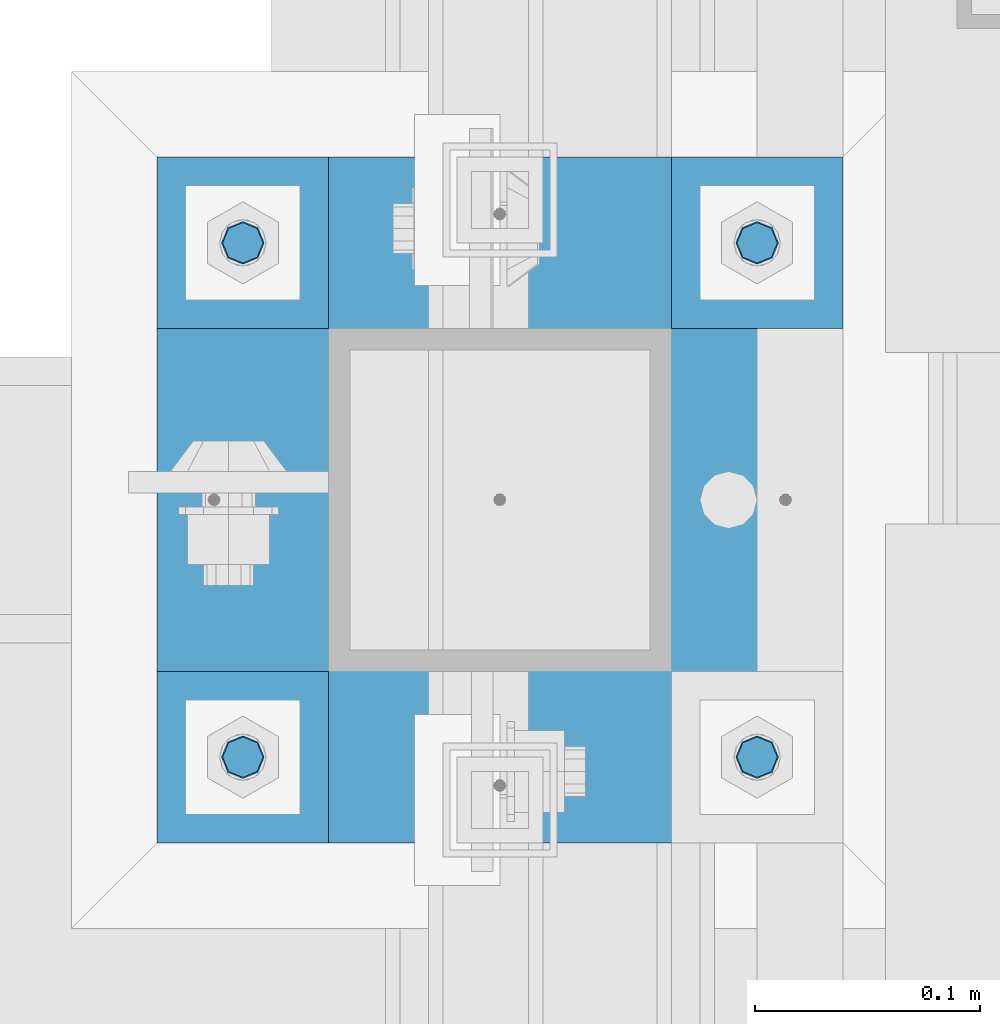
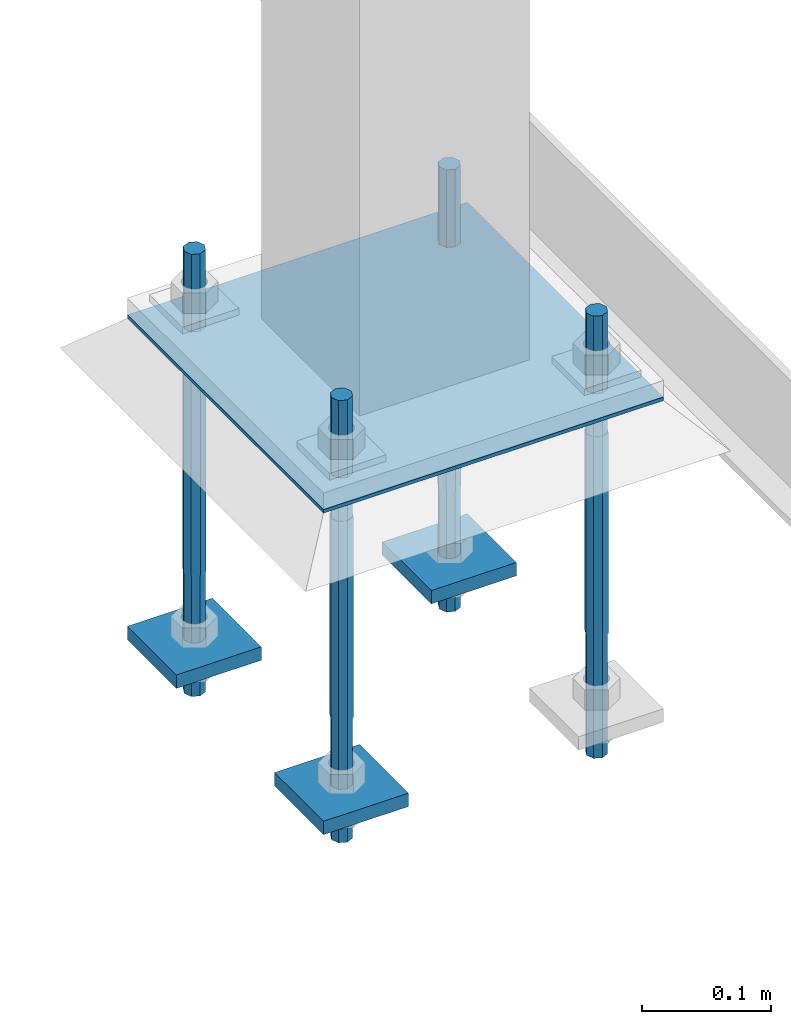
# One storey, part 2070 of 3843: 8 beams, 1 element without a shape of its own.
"""IFC2X3 building model written with IfcOpenShell, lengths in millimetres."""

from ifc_helpers import new_model, si_unit, frame, origin_with_axes, place, context, subcontext, project, spatial, faceted_brep, material, type_object, element, aggregate, save


model = new_model("IFC2X3")

# Units and contexts
model_context = context("Model", 3, precision=1e-05, world=origin_with_axes())
body_context = subcontext(model_context, "Body", "Model", "MODEL_VIEW")
ifc_project = project(units=[si_unit("LENGTHUNIT", "METRE", prefix="MILLI"), si_unit("AREAUNIT", "SQUARE_METRE"), si_unit("VOLUMEUNIT", "CUBIC_METRE"), si_unit("MASSUNIT", "GRAM", prefix="KILO"), si_unit("TIMEUNIT", "SECOND"), si_unit("PLANEANGLEUNIT", "RADIAN"), si_unit("SOLIDANGLEUNIT", "STERADIAN"), si_unit("THERMODYNAMICTEMPERATUREUNIT", "DEGREE_CELSIUS"), si_unit("LUMINOUSINTENSITYUNIT", "LUMEN")], contexts=[model_context])

# Site, building, storey
site_placement = place(None, origin_with_axes())
site = spatial("IfcSite", under=ifc_project, at=site_placement, CompositionType="ELEMENT")
building_placement = place(site_placement, origin_with_axes())
building = spatial("IfcBuilding", under=site, at=building_placement, Name="Undefined", CompositionType="ELEMENT")
storey_placement = place(building_placement, origin_with_axes())
storey = spatial("IfcBuildingStorey", under=building, at=storey_placement, Name="Undefined", CompositionType="ELEMENT", Elevation=0.0)

# Assembly, beams
assembly_placement = place(storey_placement, origin_with_axes())
assembly = element("IfcElementAssembly", 1, at=assembly_placement, inside=storey, Name="TEMPLATE", AssemblyPlace="NOTDEFINED", PredefinedType="RIGID_FRAME")
ifc_material_1 = material(Name="Undefined/F1554-GR.55")
beam_type_1 = type_object("IfcBeamType", PredefinedType="NOTDEFINED")
beam_1_placement = place(assembly_placement, frame((53105.05, 20193.0, 30480.0), z_axis=(1.0, 0.0, 0.0), x_axis=(0.0, 0.0, -1.0)))
beam_1 = element("IfcBeam", 2, at=beam_1_placement, type_object=beam_type_1, material=ifc_material_1, Name="ANCHOR_ROD", context=body_context, shape_type="Brep", body=[
    faceted_brep([(-114.300000000003, -6.36396103068546, 6.36396103067818), (-114.300000000003, 0.0, 9.0), (-114.300000000003, 6.36396103068546, 6.36396103067818), (-114.300000000003, 9.0, 0.0), (-114.300000000003, 6.36396103068546, -6.36396103067818), (-114.300000000003, 0.0, -9.0), (-114.300000000003, -6.36396103068546, -6.36396103067818), (-114.300000000003, -9.0, 0.0), (0.0, 6.36396103068546, -6.36396103067818), (0.0, 0.0, -9.0), (0.0, -6.36396103068546, -6.36396103067818), (0.0, -9.0, 0.0), (0.0, -6.36396103068546, 6.36396103067818), (0.0, 0.0, 9.0), (0.0, 6.36396103068546, 6.36396103067818), (0.0, 9.0, 0.0), (0.0, -6.73519209080405, 6.73519209079677), (-9.87109982941227e-13, 2.91322521661641e-12, 9.52499961853027), (0.0, 6.73519209080405, 6.73519209079677), (0.0, 9.52500000000146, 0.0), (0.0, 6.73519209080405, -6.73519209079677), (2.95075507493764e-12, 2.91322521661641e-12, -9.52499961853027), (0.0, -6.73519209080405, -6.73519209079677), (0.0, -9.52500000000146, 0.0), (190.5, -9.52499999999418, 0.0), (190.5, -6.73519209079677, 6.73519209080405), (190.5, 0.0, 9.52500000000146), (190.5, 6.73519209079677, 6.73519209080405), (190.5, 9.52499999999418, 0.0), (190.5, 6.73519209079677, -6.73519209080405), (190.5, 0.0, -9.52500000000146), (190.5, -6.73519209079677, -6.73519209080405), (190.5, -6.36396103068546, 6.36396103067818), (190.5, 0.0, 9.0), (190.5, 6.36396103068546, 6.36396103067818), (190.5, 9.0, 0.0), (190.5, 6.36396103068546, -6.36396103067818), (190.5, 0.0, -9.0), (190.5, -6.36396103068546, -6.36396103067818), (190.5, -9.0, 0.0), (304.799999999999, 0.0, -9.0), (304.799999999999, 6.36396103068546, -6.36396103067818), (304.799999999999, 9.0, 0.0), (304.799999999999, 6.36396103068546, 6.36396103067818), (304.799999999999, 0.0, 9.0), (304.799999999999, -6.36396103068546, 6.36396103067818), (304.799999999999, -9.0, 0.0), (304.799999999999, -6.36396103068546, -6.36396103067818)], [[[0, 1, 2, 3, 4, 5, 6, 7]], [[5, 4, 8, 9]], [[6, 5, 9, 10]], [[7, 6, 10, 11]], [[0, 7, 11, 12]], [[1, 0, 12, 13]], [[2, 1, 13, 14]], [[3, 2, 14, 15]], [[4, 3, 15, 8]], [[16, 17, 18, 19, 20, 21, 22, 23], [14, 13, 12, 11, 10, 9, 8, 15]], [[16, 23, 24, 25]], [[17, 16, 25, 26]], [[18, 17, 26, 27]], [[19, 18, 27, 28]], [[20, 19, 28, 29]], [[21, 20, 29, 30]], [[22, 21, 30, 31]], [[23, 22, 31, 24]], [[30, 29, 28, 27, 26, 25, 24, 31], [32, 33, 34, 35, 36, 37, 38, 39]], [[40, 41, 42, 43, 44, 45, 46, 47]], [[45, 44, 33, 32]], [[46, 45, 32, 39]], [[47, 46, 39, 38]], [[40, 47, 38, 37]], [[41, 40, 37, 36]], [[42, 41, 36, 35]], [[43, 42, 35, 34]], [[44, 43, 34, 33]]]),
])
beam_2_placement = place(assembly_placement, frame((53105.05, 20421.6, 30480.0), z_axis=(-1.0, 0.0, 0.0), x_axis=(0.0, 0.0, -1.0)))
beam_2 = element("IfcBeam", 3, at=beam_2_placement, type_object=beam_type_1, material=ifc_material_1, Name="ANCHOR_ROD", context=body_context, shape_type="Brep", body=[
    faceted_brep([(-114.300000000003, -6.36396103068546, 6.36396103067818), (-114.300000000003, 0.0, 9.0), (-114.300000000003, 6.36396103068546, 6.36396103067818), (-114.300000000003, 9.0, 0.0), (-114.300000000003, 6.36396103068546, -6.36396103067818), (-114.300000000003, 0.0, -9.0), (-114.300000000003, -6.36396103068546, -6.36396103067818), (-114.300000000003, -9.0, 0.0), (0.0, 6.36396103068546, -6.36396103067818), (0.0, 0.0, -9.0), (0.0, -6.36396103068546, -6.36396103067818), (0.0, -9.0, 0.0), (0.0, -6.36396103068546, 6.36396103067818), (0.0, 0.0, 9.0), (0.0, 6.36396103068546, 6.36396103067818), (0.0, 9.0, 0.0), (0.0, -6.73519209080405, 6.73519209079677), (-9.87109982941227e-13, 2.91322521661641e-12, 9.52499961853027), (0.0, 6.73519209080405, 6.73519209079677), (0.0, 9.52500000000146, 0.0), (0.0, 6.73519209080405, -6.73519209079677), (2.95075507493764e-12, 2.91322521661641e-12, -9.52499961853027), (0.0, -6.73519209080405, -6.73519209079677), (0.0, -9.52500000000146, 0.0), (190.5, -9.52499999999418, 0.0), (190.5, -6.73519209079677, 6.73519209080405), (190.5, 0.0, 9.52500000000146), (190.5, 6.73519209079677, 6.73519209080405), (190.5, 9.52499999999418, 0.0), (190.5, 6.73519209079677, -6.73519209080405), (190.5, 0.0, -9.52500000000146), (190.5, -6.73519209079677, -6.73519209080405), (190.5, -6.36396103068546, 6.36396103067818), (190.5, 0.0, 9.0), (190.5, 6.36396103068546, 6.36396103067818), (190.5, 9.0, 0.0), (190.5, 6.36396103068546, -6.36396103067818), (190.5, 0.0, -9.0), (190.5, -6.36396103068546, -6.36396103067818), (190.5, -9.0, 0.0), (304.799999999999, 0.0, -9.0), (304.799999999999, 6.36396103068546, -6.36396103067818), (304.799999999999, 9.0, 0.0), (304.799999999999, 6.36396103068546, 6.36396103067818), (304.799999999999, 0.0, 9.0), (304.799999999999, -6.36396103068546, 6.36396103067818), (304.799999999999, -9.0, 0.0), (304.799999999999, -6.36396103068546, -6.36396103067818)], [[[0, 1, 2, 3, 4, 5, 6, 7]], [[5, 4, 8, 9]], [[6, 5, 9, 10]], [[7, 6, 10, 11]], [[0, 7, 11, 12]], [[1, 0, 12, 13]], [[2, 1, 13, 14]], [[3, 2, 14, 15]], [[4, 3, 15, 8]], [[16, 17, 18, 19, 20, 21, 22, 23], [14, 13, 12, 11, 10, 9, 8, 15]], [[16, 23, 24, 25]], [[17, 16, 25, 26]], [[18, 17, 26, 27]], [[19, 18, 27, 28]], [[20, 19, 28, 29]], [[21, 20, 29, 30]], [[22, 21, 30, 31]], [[23, 22, 31, 24]], [[30, 29, 28, 27, 26, 25, 24, 31], [32, 33, 34, 35, 36, 37, 38, 39]], [[40, 41, 42, 43, 44, 45, 46, 47]], [[45, 44, 33, 32]], [[46, 45, 32, 39]], [[47, 46, 39, 38]], [[40, 47, 38, 37]], [[41, 40, 37, 36]], [[42, 41, 36, 35]], [[43, 42, 35, 34]], [[44, 43, 34, 33]]]),
])
beam_3_placement = place(assembly_placement, frame((52876.45, 20193.0, 30480.0), z_axis=(1.0, 0.0, 0.0), x_axis=(0.0, 0.0, -1.0)))
beam_3 = element("IfcBeam", 4, at=beam_3_placement, type_object=beam_type_1, material=ifc_material_1, Name="ANCHOR_ROD", context=body_context, shape_type="Brep", body=[
    faceted_brep([(-114.300000000003, -6.36396103068546, 6.36396103067818), (-114.300000000003, 0.0, 9.0), (-114.300000000003, 6.36396103068546, 6.36396103067818), (-114.300000000003, 9.0, 0.0), (-114.300000000003, 6.36396103068546, -6.36396103067818), (-114.300000000003, 0.0, -9.0), (-114.300000000003, -6.36396103068546, -6.36396103067818), (-114.300000000003, -9.0, 0.0), (0.0, 6.36396103068546, -6.36396103067818), (0.0, 0.0, -9.0), (0.0, -6.36396103068546, -6.36396103067818), (0.0, -9.0, 0.0), (0.0, -6.36396103068546, 6.36396103067818), (0.0, 0.0, 9.0), (0.0, 6.36396103068546, 6.36396103067818), (0.0, 9.0, 0.0), (0.0, -6.73519209080405, 6.73519209079677), (-9.87109982941227e-13, 2.91322521661641e-12, 9.52499961853027), (0.0, 6.73519209080405, 6.73519209079677), (0.0, 9.52500000000146, 0.0), (0.0, 6.73519209080405, -6.73519209079677), (2.95075507493764e-12, 2.91322521661641e-12, -9.52499961853027), (0.0, -6.73519209080405, -6.73519209079677), (0.0, -9.52500000000146, 0.0), (190.5, -9.52499999999418, 0.0), (190.5, -6.73519209079677, 6.73519209080405), (190.5, 0.0, 9.52500000000146), (190.5, 6.73519209079677, 6.73519209080405), (190.5, 9.52499999999418, 0.0), (190.5, 6.73519209079677, -6.73519209080405), (190.5, 0.0, -9.52500000000146), (190.5, -6.73519209079677, -6.73519209080405), (190.5, -6.36396103068546, 6.36396103067818), (190.5, 0.0, 9.0), (190.5, 6.36396103068546, 6.36396103067818), (190.5, 9.0, 0.0), (190.5, 6.36396103068546, -6.36396103067818), (190.5, 0.0, -9.0), (190.5, -6.36396103068546, -6.36396103067818), (190.5, -9.0, 0.0), (304.799999999999, 0.0, -9.0), (304.799999999999, 6.36396103068546, -6.36396103067818), (304.799999999999, 9.0, 0.0), (304.799999999999, 6.36396103068546, 6.36396103067818), (304.799999999999, 0.0, 9.0), (304.799999999999, -6.36396103068546, 6.36396103067818), (304.799999999999, -9.0, 0.0), (304.799999999999, -6.36396103068546, -6.36396103067818)], [[[0, 1, 2, 3, 4, 5, 6, 7]], [[5, 4, 8, 9]], [[6, 5, 9, 10]], [[7, 6, 10, 11]], [[0, 7, 11, 12]], [[1, 0, 12, 13]], [[2, 1, 13, 14]], [[3, 2, 14, 15]], [[4, 3, 15, 8]], [[16, 17, 18, 19, 20, 21, 22, 23], [14, 13, 12, 11, 10, 9, 8, 15]], [[16, 23, 24, 25]], [[17, 16, 25, 26]], [[18, 17, 26, 27]], [[19, 18, 27, 28]], [[20, 19, 28, 29]], [[21, 20, 29, 30]], [[22, 21, 30, 31]], [[23, 22, 31, 24]], [[30, 29, 28, 27, 26, 25, 24, 31], [32, 33, 34, 35, 36, 37, 38, 39]], [[40, 41, 42, 43, 44, 45, 46, 47]], [[45, 44, 33, 32]], [[46, 45, 32, 39]], [[47, 46, 39, 38]], [[40, 47, 38, 37]], [[41, 40, 37, 36]], [[42, 41, 36, 35]], [[43, 42, 35, 34]], [[44, 43, 34, 33]]]),
])
beam_4_placement = place(assembly_placement, frame((52876.45, 20421.6, 30480.0), z_axis=(-1.0, 0.0, 0.0), x_axis=(0.0, 0.0, -1.0)))
beam_4 = element("IfcBeam", 5, at=beam_4_placement, type_object=beam_type_1, material=ifc_material_1, Name="ANCHOR_ROD", context=body_context, shape_type="Brep", body=[
    faceted_brep([(-114.300000000003, -6.36396103068546, 6.36396103067818), (-114.300000000003, 0.0, 9.0), (-114.300000000003, 6.36396103068546, 6.36396103067818), (-114.300000000003, 9.0, 0.0), (-114.300000000003, 6.36396103068546, -6.36396103067818), (-114.300000000003, 0.0, -9.0), (-114.300000000003, -6.36396103068546, -6.36396103067818), (-114.300000000003, -9.0, 0.0), (0.0, 6.36396103068546, -6.36396103067818), (0.0, 0.0, -9.0), (0.0, -6.36396103068546, -6.36396103067818), (0.0, -9.0, 0.0), (0.0, -6.36396103068546, 6.36396103067818), (0.0, 0.0, 9.0), (0.0, 6.36396103068546, 6.36396103067818), (0.0, 9.0, 0.0), (0.0, -6.73519209080405, 6.73519209079677), (-9.87109982941227e-13, 2.91322521661641e-12, 9.52499961853027), (0.0, 6.73519209080405, 6.73519209079677), (0.0, 9.52500000000146, 0.0), (0.0, 6.73519209080405, -6.73519209079677), (2.95075507493764e-12, 2.91322521661641e-12, -9.52499961853027), (0.0, -6.73519209080405, -6.73519209079677), (0.0, -9.52500000000146, 0.0), (190.5, -9.52499999999418, 0.0), (190.5, -6.73519209079677, 6.73519209080405), (190.5, 0.0, 9.52500000000146), (190.5, 6.73519209079677, 6.73519209080405), (190.5, 9.52499999999418, 0.0), (190.5, 6.73519209079677, -6.73519209080405), (190.5, 0.0, -9.52500000000146), (190.5, -6.73519209079677, -6.73519209080405), (190.5, -6.36396103068546, 6.36396103067818), (190.5, 0.0, 9.0), (190.5, 6.36396103068546, 6.36396103067818), (190.5, 9.0, 0.0), (190.5, 6.36396103068546, -6.36396103067818), (190.5, 0.0, -9.0), (190.5, -6.36396103068546, -6.36396103067818), (190.5, -9.0, 0.0), (304.799999999999, 0.0, -9.0), (304.799999999999, 6.36396103068546, -6.36396103067818), (304.799999999999, 9.0, 0.0), (304.799999999999, 6.36396103068546, 6.36396103067818), (304.799999999999, 0.0, 9.0), (304.799999999999, -6.36396103068546, 6.36396103067818), (304.799999999999, -9.0, 0.0), (304.799999999999, -6.36396103068546, -6.36396103067818)], [[[0, 1, 2, 3, 4, 5, 6, 7]], [[5, 4, 8, 9]], [[6, 5, 9, 10]], [[7, 6, 10, 11]], [[0, 7, 11, 12]], [[1, 0, 12, 13]], [[2, 1, 13, 14]], [[3, 2, 14, 15]], [[4, 3, 15, 8]], [[16, 17, 18, 19, 20, 21, 22, 23], [14, 13, 12, 11, 10, 9, 8, 15]], [[16, 23, 24, 25]], [[17, 16, 25, 26]], [[18, 17, 26, 27]], [[19, 18, 27, 28]], [[20, 19, 28, 29]], [[21, 20, 29, 30]], [[22, 21, 30, 31]], [[23, 22, 31, 24]], [[30, 29, 28, 27, 26, 25, 24, 31], [32, 33, 34, 35, 36, 37, 38, 39]], [[40, 41, 42, 43, 44, 45, 46, 47]], [[45, 44, 33, 32]], [[46, 45, 32, 39]], [[47, 46, 39, 38]], [[40, 47, 38, 37]], [[41, 40, 37, 36]], [[42, 41, 36, 35]], [[43, 42, 35, 34]], [[44, 43, 34, 33]]]),
])
ifc_material_2 = material(Name="STEEL/A572-50")
beam_type_2 = type_object("IfcBeamType", PredefinedType="NOTDEFINED")
beam_5_placement = place(assembly_placement, frame((53143.15, 20421.6, 30219.65), z_axis=(0.0, 1.0, 0.0), x_axis=(-1.0, 0.0, 0.0)))
beam_5 = element("IfcBeam", 6, at=beam_5_placement, type_object=beam_type_2, material=ifc_material_2, context=body_context, shape_type="Brep", body=[
    faceted_brep([(0.0, 6.34999999999854, -38.1000000000058), (0.0, 6.34999999999854, 38.0999984741211), (76.1999999999971, 6.34999999999854, 38.1000000000058), (76.1999999999971, 6.34999999999854, -38.1000000000058), (0.0, -6.34999999999854, 38.0999984741211), (76.1999999999971, -6.34999999999854, 38.1000000000058), (0.0, -6.34999999999854, -38.1000000000058), (76.1999999999971, -6.34999999999854, -38.1000000000058)], [[[0, 1, 2, 3]], [[1, 4, 5, 2]], [[4, 6, 7, 5]], [[6, 0, 3, 7]], [[5, 7, 3, 2]], [[6, 4, 1, 0]]]),
])
beam_6_placement = place(assembly_placement, frame((52914.55, 20193.0, 30219.65), z_axis=(0.0, 1.0, 0.0), x_axis=(-1.0, 0.0, 0.0)))
beam_6 = element("IfcBeam", 7, at=beam_6_placement, type_object=beam_type_2, material=ifc_material_2, context=body_context, shape_type="Brep", body=[
    faceted_brep([(0.0, 6.34999999999854, -38.1000000000058), (0.0, 6.34999999999854, 38.0999984741211), (76.1999999999971, 6.34999999999854, 38.1000000000058), (76.1999999999971, 6.34999999999854, -38.1000000000058), (0.0, -6.34999999999854, 38.0999984741211), (76.1999999999971, -6.34999999999854, 38.1000000000058), (0.0, -6.34999999999854, -38.1000000000058), (76.1999999999971, -6.34999999999854, -38.1000000000058)], [[[0, 1, 2, 3]], [[1, 4, 5, 2]], [[4, 6, 7, 5]], [[6, 0, 3, 7]], [[5, 7, 3, 2]], [[6, 4, 1, 0]]]),
])
beam_7_placement = place(assembly_placement, frame((52914.55, 20421.6, 30219.65), z_axis=(0.0, 1.0, 0.0), x_axis=(-1.0, 0.0, 0.0)))
beam_7 = element("IfcBeam", 8, at=beam_7_placement, type_object=beam_type_2, material=ifc_material_2, context=body_context, shape_type="Brep", body=[
    faceted_brep([(0.0, 6.34999999999854, -38.1000000000058), (0.0, 6.34999999999854, 38.0999984741211), (76.1999999999971, 6.34999999999854, 38.1000000000058), (76.1999999999971, 6.34999999999854, -38.1000000000058), (0.0, -6.34999999999854, 38.0999984741211), (76.1999999999971, -6.34999999999854, 38.1000000000058), (0.0, -6.34999999999854, -38.1000000000058), (76.1999999999971, -6.34999999999854, -38.1000000000058)], [[[0, 1, 2, 3]], [[1, 4, 5, 2]], [[4, 6, 7, 5]], [[6, 0, 3, 7]], [[5, 7, 3, 2]], [[6, 4, 1, 0]]]),
])
beam_type_3 = type_object("IfcBeamType", PredefinedType="NOTDEFINED")
beam_8_placement = place(assembly_placement, frame((53143.1499969482, 20307.3, 30519.6875), z_axis=(0.0, -1.0, 0.0), x_axis=(-1.0, 0.0, 0.0)))
beam_8 = element("IfcBeam", 9, at=beam_8_placement, type_object=beam_type_3, material=ifc_material_2, Name="TEMPLATE", context=body_context, shape_type="Brep", body=[
    faceted_brep([(0.0, 1.58750000000146, -152.400000000001), (0.0, 1.58750000000146, 152.400000000001), (304.799993896479, 1.58750000000146, 152.400000000001), (304.799993896479, 1.58750000000146, -152.400000000001), (0.0, -1.58750000000146, 152.400000000001), (304.799993896479, -1.58750000000146, 152.400000000001), (0.0, -1.58750000000146, -152.400000000001), (304.799993896479, -1.58750000000146, -152.400000000001)], [[[0, 1, 2, 3]], [[1, 4, 5, 2]], [[4, 6, 7, 5]], [[6, 0, 3, 7]], [[5, 7, 3, 2]], [[6, 4, 1, 0]]]),
])
aggregate(assembly, [beam_1, beam_5, beam_2, beam_6, beam_3, beam_7, beam_4, beam_8])

save(model, "model.ifc")
